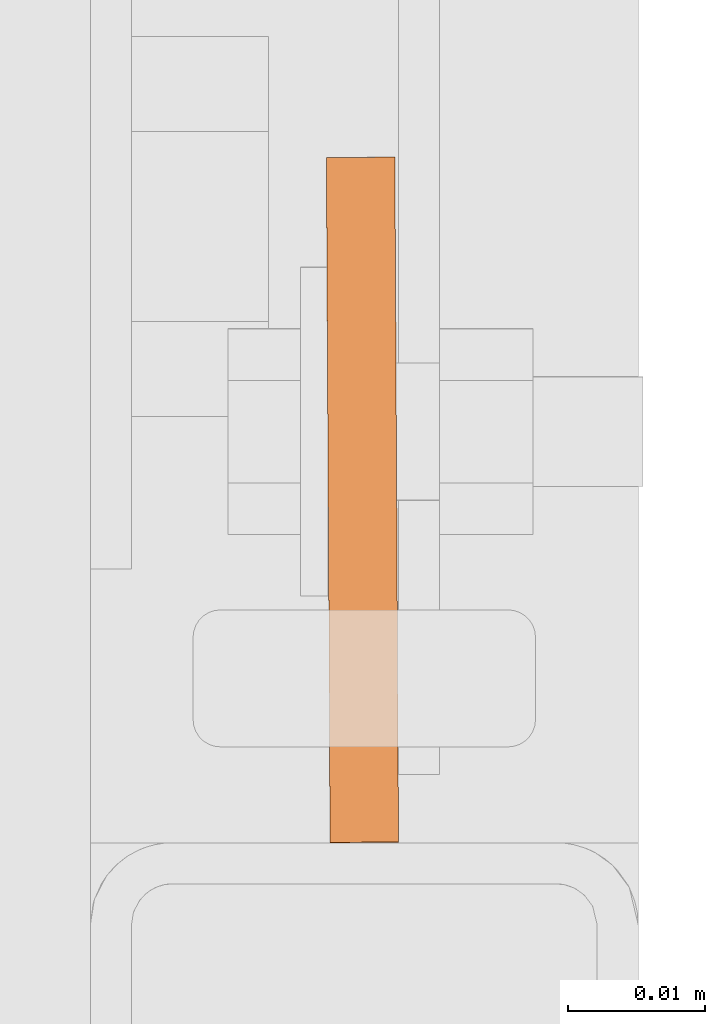
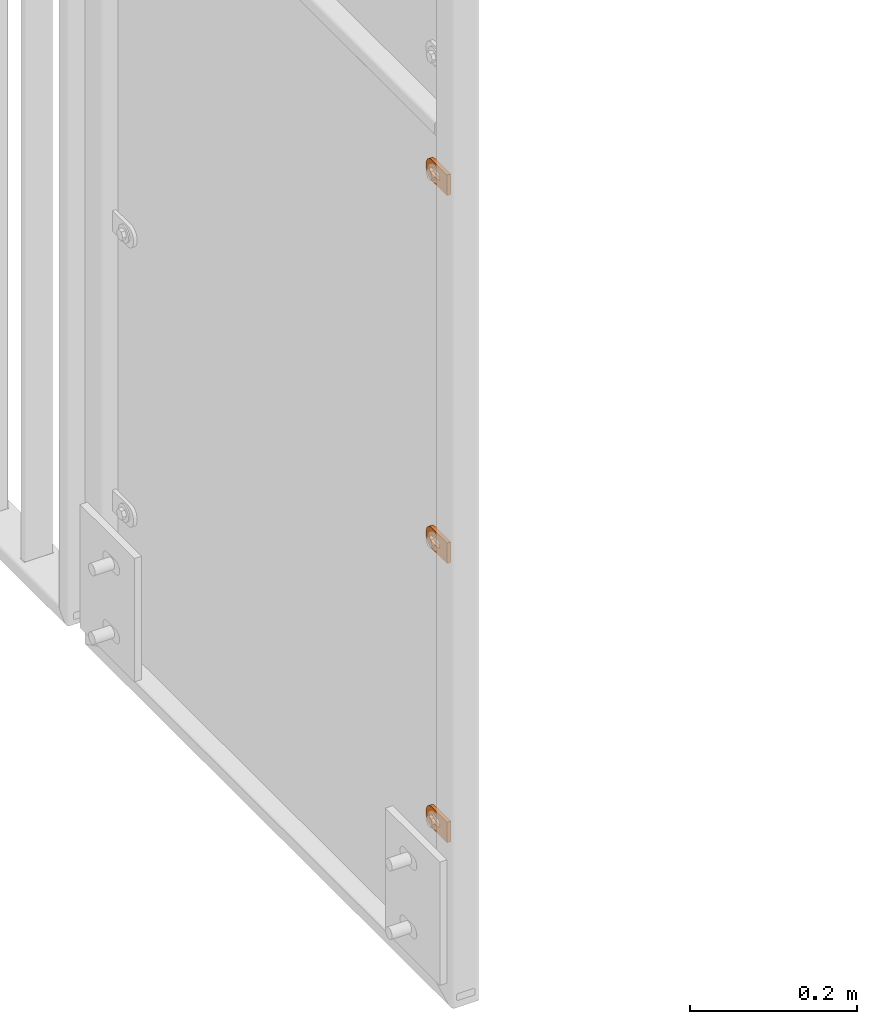
# One storey, part 143 of 156: 3 proxies, 1 element without a shape of its own.
"""IFC2X3 building model written with IfcOpenShell, lengths in millimetres."""

from ifc_helpers import new_model, si_unit, frame, origin_with_axes, place, context, subcontext, project, spatial, faceted_brep, material, type_object, element, aggregate, save


model = new_model("IFC2X3")

# Units and contexts
model_context = context("Model", 3, precision=1e-05, world=origin_with_axes())
body_context = subcontext(model_context, "Body", "Model", "MODEL_VIEW")
ifc_project = project(units=[si_unit("LENGTHUNIT", "METRE", prefix="MILLI"), si_unit("AREAUNIT", "SQUARE_METRE"), si_unit("VOLUMEUNIT", "CUBIC_METRE"), si_unit("MASSUNIT", "GRAM", prefix="KILO"), si_unit("TIMEUNIT", "SECOND"), si_unit("PLANEANGLEUNIT", "RADIAN"), si_unit("SOLIDANGLEUNIT", "STERADIAN"), si_unit("THERMODYNAMICTEMPERATUREUNIT", "DEGREE_CELSIUS"), si_unit("LUMINOUSINTENSITYUNIT", "LUMEN")], contexts=[model_context])

# Site, building, storey
site_placement = place(None, origin_with_axes())
site = spatial("IfcSite", under=ifc_project, at=site_placement, CompositionType="ELEMENT")
building_placement = place(site_placement, origin_with_axes())
building = spatial("IfcBuilding", under=site, at=building_placement, Name="Undefined", CompositionType="ELEMENT")
storey_placement = place(building_placement, origin_with_axes())
storey = spatial("IfcBuildingStorey", under=building, at=storey_placement, Name="Undefined", CompositionType="ELEMENT", Elevation=0.0)

# Assembly, proxies
assembly_placement = place(storey_placement, origin_with_axes())
assembly = element("IfcElementAssembly", 1, at=assembly_placement, inside=storey, AssemblyPlace="NOTDEFINED", PredefinedType="RIGID_FRAME")
ifc_material = material(Name="STEEL/S235JR")
building_element_proxy_type = type_object("IfcBuildingElementProxyType", Name="50", PredefinedType="NOTDEFINED")
proxy_1_placement = place(assembly_placement, frame((36514.9961242676, 20158.0426843987, 3364.99994806988), z_axis=(0.999985556002151, 0.00537473600001249, 0.0), x_axis=(-0.00537473600001187, 0.999985556002151, 1.19999999540802e-08)))
proxy_1 = element("IfcBuildingElementProxy", 2, at=proxy_1_placement, type_object=building_element_proxy_type, material=ifc_material, ObjectType="50", CompositionType="ELEMENT", context=body_context, shape_type="Brep", body=[
    faceted_brep([(37.0000004768226, -5.50000056624776, -2.49999994410609), (23.0000000446889, -5.50000056624594, -2.49999994410973), (23.0000000446889, -5.50000056624594, 2.49999994413156), (37.000000476819, -5.50000056624776, 2.49999994413338), (21.9270028173814, -5.39431966841403, -2.49999994410973), (21.9270028173778, -5.39431966841403, 2.49999994412792), (20.895240828384, -5.0813375413436, -2.49999994411155), (20.895240828384, -5.0813375413436, 2.49999994412974), (19.9443642049955, -4.5730831474084, -2.49999994410973), (19.9443642049919, -4.5730831474084, 2.49999994412792), (19.1109124571012, -3.88908818364325, -2.49999994411155), (19.1109124571012, -3.88908818364325, 2.49999994412792), (18.4269174933361, -3.05563643574806, -2.49999994411155), (18.4269174933361, -3.05563643574806, 2.4999999441261), (17.9186630994009, -2.1047579497108, -2.49999994411155), (17.9186630994009, -2.1047579497108, 2.49999994412428), (17.6056809723377, -1.07299596071425, -2.49999994411337), (17.6056809723341, -1.07299596071425, 2.4999999441261), (17.5000000745022, 3.3527521736687e-07, -2.49999994411519), (17.5000000745058, 3.3527521736687e-07, 2.49999994412428), (17.6056809723377, 1.07299663126287, -2.49999994411701), (17.6056809723377, 1.07299663126287, 2.49999994412428), (17.9186630994154, 2.10475862026124, -2.49999994411701), (17.9186630994118, 2.10475862026124, 2.49999994412246), (18.426917493347, 3.05563617497592, -2.49999994411701), (18.426917493347, 3.05563617497592, 2.49999994412246), (19.1109124571158, 3.88908699154672, -2.49999994411883), (19.1109124571121, 3.88908699154672, 2.49999994412065), (19.9443642050101, 4.57308288663444, -2.49999994411701), (19.9443642050064, 4.57308288663444, 2.49999994412065), (20.8952408283985, 5.08133728056964, -2.49999994411883), (20.8952408283985, 5.08133728056964, 2.49999994412065), (21.9270028173996, 5.39431940764007, -2.49999994411883), (21.927002817396, 5.39431940764007, 2.49999994412065), (23.0000000447108, 5.50000030547199, -2.49999994411883), (23.0000000447071, 5.50000030547199, 2.49999994412246), (37.0000004768408, 5.50000030547017, -2.49999994411519), (37.0000004768408, 5.50000030547017, 2.49999994412428), (38.0729958415031, 5.39431940763825, -2.49999994411519), (38.0729958414995, 5.39431940763825, 2.49999994412428), (39.1047596931458, 5.08133728056691, -2.49999994411337), (39.1047596931421, 5.08133728056691, 2.49999994412428), (40.0556363165415, 4.57308288663171, -2.49999994411519), (40.0556363165379, 4.57308288663171, 2.4999999441261), (40.8890880644285, 3.8890869915449, -2.49999994411337), (40.8890880644285, 3.8890869915449, 2.49999994412792), (41.5730811655449, 3.05563617497228, -2.49999994411337), (41.5730811655449, 3.05563617497228, 2.4999999441261), (42.0813374221252, 2.1047586202576, -2.49999994411155), (42.0813374221252, 2.1047586202576, 2.49999994412792), (42.3943176865469, 1.07299663126014, -2.49999994410973), (42.3943176865469, 1.07299663126014, 2.49999994412974), (42.5000004470239, 3.35271579388063e-07, -2.49999994410973), (42.5000004470276, 3.35271579388063e-07, 2.49999994412974), (42.3943176865469, -1.07299596071698, -2.49999994410791), (42.3943176865432, -1.07299596071698, 2.49999994413156), (42.0813374221179, -2.10475794971444, -2.49999994410791), (42.0813374221143, -2.10475794971444, 2.49999994413338), (41.5730811655376, -3.05563643575169, -2.49999994410791), (41.5730811655339, -3.05563643575169, 2.49999994413156), (40.8890880644176, -3.88908818364507, -2.49999994410609), (40.889088064414, -3.88908818364507, 2.49999994413338), (40.0556363165233, -4.57308314741113, -2.49999994410791), (40.0556363165233, -4.57308314741113, 2.49999994413338), (39.1047596931276, -5.08133754134633, -2.49999994410609), (39.1047596931276, -5.08133754134633, 2.49999994413338), (38.072995841485, -5.39431966841585, -2.49999994410609), (38.072995841485, -5.39431966841585, 2.49999994413156), (37.0000004768044, -14.9999993294514, 2.49999994414065), (39.5361743867034, -14.7502093017147, 2.49999994414065), (41.9748835265273, -14.0104337036646, 2.49999994414065), (44.222414493528, -12.8091058135078, 2.49999994414247), (46.192388981548, -11.1923875659759, 2.49999994413884), (47.809105366443, -9.22241307795593, 2.49999994413884), (49.010433256597, -6.97488397360394, 2.49999994413702), (49.7502088546535, -4.53617483378002, 2.49999994413338), (50.0000007450435, -2.00000092387745, 2.49999994413338), (50.0000007450471, 1.99999973177364, 2.49999994412974), (49.7502088546717, 4.53617457299879, 2.4999999441261), (49.0104332566261, 6.97488464414528, 2.4999999441261), (47.8091053664721, 9.2224128171747, 2.49999994412428), (46.192388981588, 11.1923882365172, 2.49999994412065), (44.2224144935717, 12.8091048542365, 2.49999994411883), (41.9748835265782, 14.0104339085483, 2.49999994411883), (39.5361743867543, 14.7502086334816, 2.49999994411701), (37.0000004768553, 14.9999999999964, 2.49999994411519), (2.91038304567337e-11, 15.0000000000009, 2.49999994410791), (-2.18278728425503e-11, -14.9999993294468, 2.49999994413338), (3.27418092638254e-11, 15.0000000000009, -2.49999994413156), (-2.18278728425503e-11, -14.9999993294468, -2.49999994410791), (37.0000004768008, -14.9999993294514, -2.49999994409882), (39.5361743867034, -14.7502093017147, -2.49999994409882), (41.9748835265309, -14.0104337036646, -2.499999944097), (44.222414493528, -12.8091058135078, -2.49999994409882), (46.1923889815516, -11.1923875659759, -2.49999994409882), (47.8091053664393, -9.22241307795593, -2.49999994410064), (49.0104332566007, -6.97488397360394, -2.49999994410246), (49.7502088546535, -4.53617483378002, -2.49999994410609), (50.0000007450435, -2.00000092387745, -2.49999994410609), (50.0000007450508, 1.99999973177364, -2.49999994410973), (49.750208854668, 4.53617457299879, -2.49999994411155), (49.0104332566261, 6.97488464414528, -2.49999994411337), (47.8091053664721, 9.2224128171747, -2.49999994411519), (46.1923889815916, 11.1923882365172, -2.49999994411883), (44.2224144935717, 12.8091048542365, -2.49999994411883), (41.9748835265782, 14.0104339085483, -2.49999994412065), (39.5361743867579, 14.7502086334816, -2.49999994412246), (37.000000476859, 14.9999999999964, -2.49999994412428)], [[[0, 1, 2, 3]], [[1, 4, 5, 2]], [[4, 6, 7, 5]], [[6, 8, 9, 7]], [[8, 10, 11, 9]], [[10, 12, 13, 11]], [[12, 14, 15, 13]], [[14, 16, 17, 15]], [[16, 18, 19, 17]], [[18, 20, 21, 19]], [[20, 22, 23, 21]], [[22, 24, 25, 23]], [[24, 26, 27, 25]], [[26, 28, 29, 27]], [[28, 30, 31, 29]], [[30, 32, 33, 31]], [[32, 34, 35, 33]], [[34, 36, 37, 35]], [[36, 38, 39, 37]], [[38, 40, 41, 39]], [[40, 42, 43, 41]], [[42, 44, 45, 43]], [[44, 46, 47, 45]], [[46, 48, 49, 47]], [[48, 50, 51, 49]], [[50, 52, 53, 51]], [[52, 54, 55, 53]], [[54, 56, 57, 55]], [[56, 58, 59, 57]], [[58, 60, 61, 59]], [[60, 62, 63, 61]], [[62, 64, 65, 63]], [[64, 66, 67, 65]], [[66, 0, 3, 67]], [[68, 69, 70, 71, 72, 73, 74, 75, 76, 77, 78, 79, 80, 81, 82, 83, 84, 85, 86, 87], [5, 7, 9, 11, 13, 15, 17, 19, 21, 23, 25, 27, 29, 31, 33, 35, 37, 39, 41, 43, 45, 47, 49, 51, 53, 55, 57, 59, 61, 63, 65, 67, 3, 2]], [[86, 88, 89, 87]], [[87, 89, 90, 68]], [[68, 90, 91, 69]], [[69, 91, 92, 70]], [[70, 92, 93, 71]], [[71, 93, 94, 72]], [[72, 94, 95, 73]], [[73, 95, 96, 74]], [[74, 96, 97, 75]], [[75, 97, 98, 76]], [[76, 98, 99, 77]], [[77, 99, 100, 78]], [[78, 100, 101, 79]], [[79, 101, 102, 80]], [[80, 102, 103, 81]], [[81, 103, 104, 82]], [[82, 104, 105, 83]], [[83, 105, 106, 84]], [[84, 106, 107, 85]], [[85, 107, 88, 86]], [[105, 104, 103, 102, 101, 100, 99, 98, 97, 96, 95, 94, 93, 92, 91, 90, 89, 88, 107, 106], [60, 58, 56, 54, 52, 50, 48, 46, 44, 42, 40, 38, 36, 34, 32, 30, 28, 26, 24, 22, 20, 18, 16, 14, 12, 10, 8, 6, 4, 1, 0, 66, 64, 62]]]),
])
proxy_2_placement = place(assembly_placement, frame((36514.9961242676, 20158.0426843987, 3901.62851904448), z_axis=(0.999985556002151, 0.00537473600001249, 0.0), x_axis=(-0.00537473600001187, 0.999985556002151, 1.19999999540802e-08)))
proxy_2 = element("IfcBuildingElementProxy", 3, at=proxy_2_placement, type_object=building_element_proxy_type, material=ifc_material, ObjectType="50", CompositionType="ELEMENT", context=body_context, shape_type="Brep", body=[
    faceted_brep([(37.0000004768226, -5.50000056624776, -2.49999994410609), (23.0000000446889, -5.50000056624594, -2.49999994410973), (23.0000000446889, -5.50000056624594, 2.49999994413156), (37.000000476819, -5.50000056624776, 2.49999994413338), (21.9270028173814, -5.39431966841403, -2.49999994410973), (21.9270028173778, -5.39431966841403, 2.49999994412792), (20.895240828384, -5.0813375413436, -2.49999994411155), (20.895240828384, -5.0813375413436, 2.49999994412974), (19.9443642049955, -4.5730831474084, -2.49999994410973), (19.9443642049919, -4.5730831474084, 2.49999994412792), (19.1109124571012, -3.88908818364325, -2.49999994411155), (19.1109124571012, -3.88908818364325, 2.49999994412792), (18.4269174933361, -3.05563643574806, -2.49999994411155), (18.4269174933361, -3.05563643574806, 2.4999999441261), (17.9186630994009, -2.1047579497108, -2.49999994411155), (17.9186630994009, -2.1047579497108, 2.49999994412428), (17.6056809723377, -1.07299596071425, -2.49999994411337), (17.6056809723341, -1.07299596071425, 2.4999999441261), (17.5000000745022, 3.3527521736687e-07, -2.49999994411519), (17.5000000745058, 3.3527521736687e-07, 2.49999994412428), (17.6056809723377, 1.07299663126287, -2.49999994411701), (17.6056809723377, 1.07299663126287, 2.49999994412428), (17.9186630994154, 2.10475862026124, -2.49999994411701), (17.9186630994118, 2.10475862026124, 2.49999994412246), (18.426917493347, 3.05563617497592, -2.49999994411701), (18.426917493347, 3.05563617497592, 2.49999994412246), (19.1109124571158, 3.88908699154672, -2.49999994411883), (19.1109124571121, 3.88908699154672, 2.49999994412065), (19.9443642050101, 4.57308288663444, -2.49999994411701), (19.9443642050064, 4.57308288663444, 2.49999994412065), (20.8952408283985, 5.08133728056964, -2.49999994411883), (20.8952408283985, 5.08133728056964, 2.49999994412065), (21.9270028173996, 5.39431940764007, -2.49999994411883), (21.927002817396, 5.39431940764007, 2.49999994412065), (23.0000000447108, 5.50000030547199, -2.49999994411883), (23.0000000447071, 5.50000030547199, 2.49999994412246), (37.0000004768408, 5.50000030547017, -2.49999994411519), (37.0000004768408, 5.50000030547017, 2.49999994412428), (38.0729958415031, 5.39431940763825, -2.49999994411519), (38.0729958414995, 5.39431940763825, 2.49999994412428), (39.1047596931458, 5.08133728056691, -2.49999994411337), (39.1047596931421, 5.08133728056691, 2.49999994412428), (40.0556363165415, 4.57308288663171, -2.49999994411519), (40.0556363165379, 4.57308288663171, 2.4999999441261), (40.8890880644285, 3.8890869915449, -2.49999994411337), (40.8890880644285, 3.8890869915449, 2.49999994412792), (41.5730811655449, 3.05563617497228, -2.49999994411337), (41.5730811655449, 3.05563617497228, 2.4999999441261), (42.0813374221252, 2.1047586202576, -2.49999994411155), (42.0813374221252, 2.1047586202576, 2.49999994412792), (42.3943176865469, 1.07299663126014, -2.49999994410973), (42.3943176865469, 1.07299663126014, 2.49999994412974), (42.5000004470239, 3.35271579388063e-07, -2.49999994410973), (42.5000004470276, 3.35271579388063e-07, 2.49999994412974), (42.3943176865469, -1.07299596071698, -2.49999994410791), (42.3943176865432, -1.07299596071698, 2.49999994413156), (42.0813374221179, -2.10475794971444, -2.49999994410791), (42.0813374221143, -2.10475794971444, 2.49999994413338), (41.5730811655376, -3.05563643575169, -2.49999994410791), (41.5730811655339, -3.05563643575169, 2.49999994413156), (40.8890880644176, -3.88908818364507, -2.49999994410609), (40.889088064414, -3.88908818364507, 2.49999994413338), (40.0556363165233, -4.57308314741113, -2.49999994410791), (40.0556363165233, -4.57308314741113, 2.49999994413338), (39.1047596931276, -5.08133754134633, -2.49999994410609), (39.1047596931276, -5.08133754134633, 2.49999994413338), (38.072995841485, -5.39431966841585, -2.49999994410609), (38.072995841485, -5.39431966841585, 2.49999994413156), (37.0000004768044, -14.9999993294514, 2.49999994414065), (39.5361743867034, -14.7502093017147, 2.49999994414065), (41.9748835265273, -14.0104337036646, 2.49999994414065), (44.222414493528, -12.8091058135078, 2.49999994414247), (46.192388981548, -11.1923875659759, 2.49999994413884), (47.809105366443, -9.22241307795593, 2.49999994413884), (49.010433256597, -6.97488397360394, 2.49999994413702), (49.7502088546535, -4.53617483378002, 2.49999994413338), (50.0000007450435, -2.00000092387745, 2.49999994413338), (50.0000007450471, 1.99999973177364, 2.49999994412974), (49.7502088546717, 4.53617457299879, 2.4999999441261), (49.0104332566261, 6.97488464414528, 2.4999999441261), (47.8091053664721, 9.2224128171747, 2.49999994412428), (46.192388981588, 11.1923882365172, 2.49999994412065), (44.2224144935717, 12.8091048542365, 2.49999994411883), (41.9748835265782, 14.0104339085483, 2.49999994411883), (39.5361743867543, 14.7502086334816, 2.49999994411701), (37.0000004768553, 14.9999999999964, 2.49999994411519), (2.91038304567337e-11, 15.0000000000009, 2.49999994410791), (-2.18278728425503e-11, -14.9999993294468, 2.49999994413338), (3.27418092638254e-11, 15.0000000000009, -2.49999994413156), (-2.18278728425503e-11, -14.9999993294468, -2.49999994410791), (37.0000004768008, -14.9999993294514, -2.49999994409882), (39.5361743867034, -14.7502093017147, -2.49999994409882), (41.9748835265309, -14.0104337036646, -2.499999944097), (44.222414493528, -12.8091058135078, -2.49999994409882), (46.1923889815516, -11.1923875659759, -2.49999994409882), (47.8091053664393, -9.22241307795593, -2.49999994410064), (49.0104332566007, -6.97488397360394, -2.49999994410246), (49.7502088546535, -4.53617483378002, -2.49999994410609), (50.0000007450435, -2.00000092387745, -2.49999994410609), (50.0000007450508, 1.99999973177364, -2.49999994410973), (49.750208854668, 4.53617457299879, -2.49999994411155), (49.0104332566261, 6.97488464414528, -2.49999994411337), (47.8091053664721, 9.2224128171747, -2.49999994411519), (46.1923889815916, 11.1923882365172, -2.49999994411883), (44.2224144935717, 12.8091048542365, -2.49999994411883), (41.9748835265782, 14.0104339085483, -2.49999994412065), (39.5361743867579, 14.7502086334816, -2.49999994412246), (37.000000476859, 14.9999999999964, -2.49999994412428)], [[[0, 1, 2, 3]], [[1, 4, 5, 2]], [[4, 6, 7, 5]], [[6, 8, 9, 7]], [[8, 10, 11, 9]], [[10, 12, 13, 11]], [[12, 14, 15, 13]], [[14, 16, 17, 15]], [[16, 18, 19, 17]], [[18, 20, 21, 19]], [[20, 22, 23, 21]], [[22, 24, 25, 23]], [[24, 26, 27, 25]], [[26, 28, 29, 27]], [[28, 30, 31, 29]], [[30, 32, 33, 31]], [[32, 34, 35, 33]], [[34, 36, 37, 35]], [[36, 38, 39, 37]], [[38, 40, 41, 39]], [[40, 42, 43, 41]], [[42, 44, 45, 43]], [[44, 46, 47, 45]], [[46, 48, 49, 47]], [[48, 50, 51, 49]], [[50, 52, 53, 51]], [[52, 54, 55, 53]], [[54, 56, 57, 55]], [[56, 58, 59, 57]], [[58, 60, 61, 59]], [[60, 62, 63, 61]], [[62, 64, 65, 63]], [[64, 66, 67, 65]], [[66, 0, 3, 67]], [[68, 69, 70, 71, 72, 73, 74, 75, 76, 77, 78, 79, 80, 81, 82, 83, 84, 85, 86, 87], [5, 7, 9, 11, 13, 15, 17, 19, 21, 23, 25, 27, 29, 31, 33, 35, 37, 39, 41, 43, 45, 47, 49, 51, 53, 55, 57, 59, 61, 63, 65, 67, 3, 2]], [[86, 88, 89, 87]], [[87, 89, 90, 68]], [[68, 90, 91, 69]], [[69, 91, 92, 70]], [[70, 92, 93, 71]], [[71, 93, 94, 72]], [[72, 94, 95, 73]], [[73, 95, 96, 74]], [[74, 96, 97, 75]], [[75, 97, 98, 76]], [[76, 98, 99, 77]], [[77, 99, 100, 78]], [[78, 100, 101, 79]], [[79, 101, 102, 80]], [[80, 102, 103, 81]], [[81, 103, 104, 82]], [[82, 104, 105, 83]], [[83, 105, 106, 84]], [[84, 106, 107, 85]], [[85, 107, 88, 86]], [[105, 104, 103, 102, 101, 100, 99, 98, 97, 96, 95, 94, 93, 92, 91, 90, 89, 88, 107, 106], [60, 58, 56, 54, 52, 50, 48, 46, 44, 42, 40, 38, 36, 34, 32, 30, 28, 26, 24, 22, 20, 18, 16, 14, 12, 10, 8, 6, 4, 1, 0, 66, 64, 62]]]),
])
proxy_3_placement = place(assembly_placement, frame((36514.9961242676, 20158.0106561273, 2957.71209838867), z_axis=(0.999985556002151, 0.00537473600001249, 0.0), x_axis=(-0.00537473600001187, 0.999985556002151, 1.19999999540802e-08)))
proxy_3 = element("IfcBuildingElementProxy", 4, at=proxy_3_placement, type_object=building_element_proxy_type, material=ifc_material, ObjectType="50", CompositionType="ELEMENT", context=body_context, shape_type="Brep", body=[
    faceted_brep([(37.0000004768226, -5.50000056624776, -2.49999994410609), (23.0000000446889, -5.50000056624594, -2.49999994410973), (23.0000000446889, -5.50000056624594, 2.49999994413156), (37.000000476819, -5.50000056624776, 2.49999994413338), (21.9270028173814, -5.39431966841403, -2.49999994410973), (21.9270028173778, -5.39431966841403, 2.49999994412792), (20.895240828384, -5.0813375413436, -2.49999994411155), (20.895240828384, -5.0813375413436, 2.49999994412974), (19.9443642049955, -4.5730831474084, -2.49999994410973), (19.9443642049919, -4.5730831474084, 2.49999994412792), (19.1109124571012, -3.88908818364325, -2.49999994411155), (19.1109124571012, -3.88908818364325, 2.49999994412792), (18.4269174933361, -3.05563643574806, -2.49999994411155), (18.4269174933361, -3.05563643574806, 2.4999999441261), (17.9186630994009, -2.1047579497108, -2.49999994411155), (17.9186630994009, -2.1047579497108, 2.49999994412428), (17.6056809723377, -1.07299596071425, -2.49999994411337), (17.6056809723341, -1.07299596071425, 2.4999999441261), (17.5000000745022, 3.3527521736687e-07, -2.49999994411519), (17.5000000745058, 3.3527521736687e-07, 2.49999994412428), (17.6056809723377, 1.07299663126287, -2.49999994411701), (17.6056809723377, 1.07299663126287, 2.49999994412428), (17.9186630994154, 2.10475862026124, -2.49999994411701), (17.9186630994118, 2.10475862026124, 2.49999994412246), (18.426917493347, 3.05563617497592, -2.49999994411701), (18.426917493347, 3.05563617497592, 2.49999994412246), (19.1109124571158, 3.88908699154672, -2.49999994411883), (19.1109124571121, 3.88908699154672, 2.49999994412065), (19.9443642050101, 4.57308288663444, -2.49999994411701), (19.9443642050064, 4.57308288663444, 2.49999994412065), (20.8952408283985, 5.08133728056964, -2.49999994411883), (20.8952408283985, 5.08133728056964, 2.49999994412065), (21.9270028173996, 5.39431940764007, -2.49999994411883), (21.927002817396, 5.39431940764007, 2.49999994412065), (23.0000000447108, 5.50000030547199, -2.49999994411883), (23.0000000447071, 5.50000030547199, 2.49999994412246), (37.0000004768408, 5.50000030547017, -2.49999994411519), (37.0000004768408, 5.50000030547017, 2.49999994412428), (38.0729958415031, 5.39431940763825, -2.49999994411519), (38.0729958414995, 5.39431940763825, 2.49999994412428), (39.1047596931458, 5.08133728056691, -2.49999994411337), (39.1047596931421, 5.08133728056691, 2.49999994412428), (40.0556363165415, 4.57308288663171, -2.49999994411519), (40.0556363165379, 4.57308288663171, 2.4999999441261), (40.8890880644285, 3.8890869915449, -2.49999994411337), (40.8890880644285, 3.8890869915449, 2.49999994412792), (41.5730811655449, 3.05563617497228, -2.49999994411337), (41.5730811655449, 3.05563617497228, 2.4999999441261), (42.0813374221252, 2.1047586202576, -2.49999994411155), (42.0813374221252, 2.1047586202576, 2.49999994412792), (42.3943176865469, 1.07299663126014, -2.49999994410973), (42.3943176865469, 1.07299663126014, 2.49999994412974), (42.5000004470239, 3.35271579388063e-07, -2.49999994410973), (42.5000004470276, 3.35271579388063e-07, 2.49999994412974), (42.3943176865469, -1.07299596071698, -2.49999994410791), (42.3943176865432, -1.07299596071698, 2.49999994413156), (42.0813374221179, -2.10475794971444, -2.49999994410791), (42.0813374221143, -2.10475794971444, 2.49999994413338), (41.5730811655376, -3.05563643575169, -2.49999994410791), (41.5730811655339, -3.05563643575169, 2.49999994413156), (40.8890880644176, -3.88908818364507, -2.49999994410609), (40.889088064414, -3.88908818364507, 2.49999994413338), (40.0556363165233, -4.57308314741113, -2.49999994410791), (40.0556363165233, -4.57308314741113, 2.49999994413338), (39.1047596931276, -5.08133754134633, -2.49999994410609), (39.1047596931276, -5.08133754134633, 2.49999994413338), (38.072995841485, -5.39431966841585, -2.49999994410609), (38.072995841485, -5.39431966841585, 2.49999994413156), (37.0000004768044, -14.9999993294514, 2.49999994414065), (39.5361743867034, -14.7502093017147, 2.49999994414065), (41.9748835265273, -14.0104337036646, 2.49999994414065), (44.222414493528, -12.8091058135078, 2.49999994414247), (46.192388981548, -11.1923875659759, 2.49999994413884), (47.809105366443, -9.22241307795593, 2.49999994413884), (49.010433256597, -6.97488397360394, 2.49999994413702), (49.7502088546535, -4.53617483378002, 2.49999994413338), (50.0000007450435, -2.00000092387745, 2.49999994413338), (50.0000007450471, 1.99999973177364, 2.49999994412974), (49.7502088546717, 4.53617457299879, 2.4999999441261), (49.0104332566261, 6.97488464414528, 2.4999999441261), (47.8091053664721, 9.2224128171747, 2.49999994412428), (46.192388981588, 11.1923882365172, 2.49999994412065), (44.2224144935717, 12.8091048542365, 2.49999994411883), (41.9748835265782, 14.0104339085483, 2.49999994411883), (39.5361743867543, 14.7502086334816, 2.49999994411701), (37.0000004768553, 14.9999999999964, 2.49999994411519), (2.91038304567337e-11, 15.0000000000009, 2.49999994410791), (-2.18278728425503e-11, -14.9999993294468, 2.49999994413338), (3.27418092638254e-11, 15.0000000000009, -2.49999994413156), (-2.18278728425503e-11, -14.9999993294468, -2.49999994410791), (37.0000004768008, -14.9999993294514, -2.49999994409882), (39.5361743867034, -14.7502093017147, -2.49999994409882), (41.9748835265309, -14.0104337036646, -2.499999944097), (44.222414493528, -12.8091058135078, -2.49999994409882), (46.1923889815516, -11.1923875659759, -2.49999994409882), (47.8091053664393, -9.22241307795593, -2.49999994410064), (49.0104332566007, -6.97488397360394, -2.49999994410246), (49.7502088546535, -4.53617483378002, -2.49999994410609), (50.0000007450435, -2.00000092387745, -2.49999994410609), (50.0000007450508, 1.99999973177364, -2.49999994410973), (49.750208854668, 4.53617457299879, -2.49999994411155), (49.0104332566261, 6.97488464414528, -2.49999994411337), (47.8091053664721, 9.2224128171747, -2.49999994411519), (46.1923889815916, 11.1923882365172, -2.49999994411883), (44.2224144935717, 12.8091048542365, -2.49999994411883), (41.9748835265782, 14.0104339085483, -2.49999994412065), (39.5361743867579, 14.7502086334816, -2.49999994412246), (37.000000476859, 14.9999999999964, -2.49999994412428)], [[[0, 1, 2, 3]], [[1, 4, 5, 2]], [[4, 6, 7, 5]], [[6, 8, 9, 7]], [[8, 10, 11, 9]], [[10, 12, 13, 11]], [[12, 14, 15, 13]], [[14, 16, 17, 15]], [[16, 18, 19, 17]], [[18, 20, 21, 19]], [[20, 22, 23, 21]], [[22, 24, 25, 23]], [[24, 26, 27, 25]], [[26, 28, 29, 27]], [[28, 30, 31, 29]], [[30, 32, 33, 31]], [[32, 34, 35, 33]], [[34, 36, 37, 35]], [[36, 38, 39, 37]], [[38, 40, 41, 39]], [[40, 42, 43, 41]], [[42, 44, 45, 43]], [[44, 46, 47, 45]], [[46, 48, 49, 47]], [[48, 50, 51, 49]], [[50, 52, 53, 51]], [[52, 54, 55, 53]], [[54, 56, 57, 55]], [[56, 58, 59, 57]], [[58, 60, 61, 59]], [[60, 62, 63, 61]], [[62, 64, 65, 63]], [[64, 66, 67, 65]], [[66, 0, 3, 67]], [[68, 69, 70, 71, 72, 73, 74, 75, 76, 77, 78, 79, 80, 81, 82, 83, 84, 85, 86, 87], [5, 7, 9, 11, 13, 15, 17, 19, 21, 23, 25, 27, 29, 31, 33, 35, 37, 39, 41, 43, 45, 47, 49, 51, 53, 55, 57, 59, 61, 63, 65, 67, 3, 2]], [[86, 88, 89, 87]], [[87, 89, 90, 68]], [[68, 90, 91, 69]], [[69, 91, 92, 70]], [[70, 92, 93, 71]], [[71, 93, 94, 72]], [[72, 94, 95, 73]], [[73, 95, 96, 74]], [[74, 96, 97, 75]], [[75, 97, 98, 76]], [[76, 98, 99, 77]], [[77, 99, 100, 78]], [[78, 100, 101, 79]], [[79, 101, 102, 80]], [[80, 102, 103, 81]], [[81, 103, 104, 82]], [[82, 104, 105, 83]], [[83, 105, 106, 84]], [[84, 106, 107, 85]], [[85, 107, 88, 86]], [[105, 104, 103, 102, 101, 100, 99, 98, 97, 96, 95, 94, 93, 92, 91, 90, 89, 88, 107, 106], [60, 58, 56, 54, 52, 50, 48, 46, 44, 42, 40, 38, 36, 34, 32, 30, 28, 26, 24, 22, 20, 18, 16, 14, 12, 10, 8, 6, 4, 1, 0, 66, 64, 62]]]),
])
aggregate(assembly, [proxy_1, proxy_2, proxy_3])

save(model, "model.ifc")
